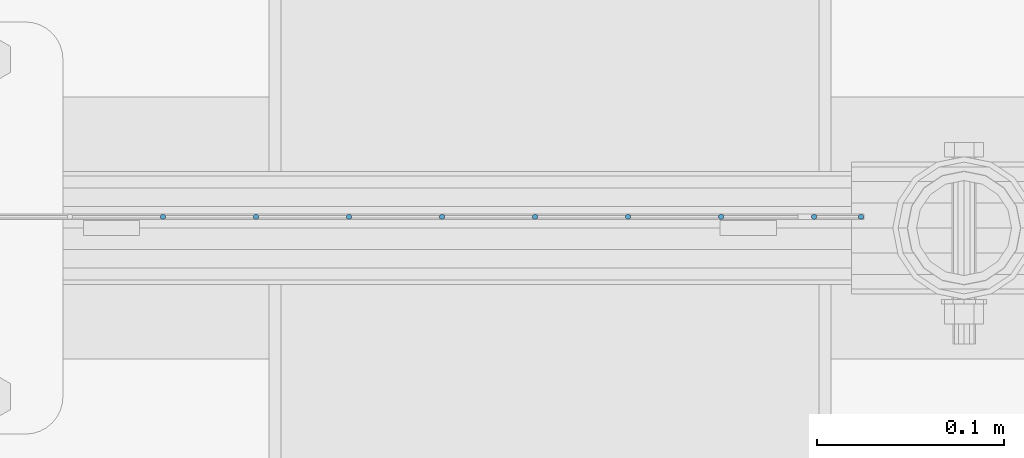
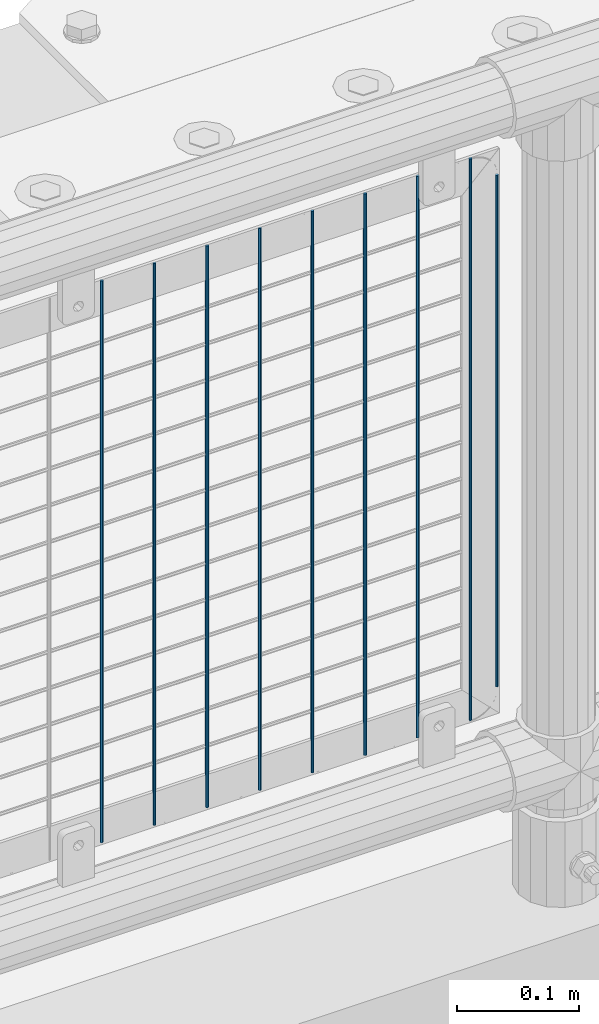
# One storey, part 64 of 208: 9 columns.
"""IFC2X3 building model written with IfcOpenShell, lengths in millimetres."""

from ifc_helpers import new_model, si_unit, frame, origin_with_axes, place, context, subcontext, project, spatial, faceted_brep, material, type_object, element, save


model = new_model("IFC2X3")

# Units and contexts
model_context = context("Model", 3, precision=1e-05, world=origin_with_axes())
body_context = subcontext(model_context, "Body", "Model", "MODEL_VIEW")
ifc_project = project(units=[si_unit("LENGTHUNIT", "METRE", prefix="MILLI"), si_unit("AREAUNIT", "SQUARE_METRE"), si_unit("VOLUMEUNIT", "CUBIC_METRE"), si_unit("MASSUNIT", "GRAM", prefix="KILO"), si_unit("TIMEUNIT", "SECOND"), si_unit("PLANEANGLEUNIT", "RADIAN"), si_unit("SOLIDANGLEUNIT", "STERADIAN"), si_unit("THERMODYNAMICTEMPERATUREUNIT", "DEGREE_CELSIUS"), si_unit("LUMINOUSINTENSITYUNIT", "LUMEN")], contexts=[model_context])

# Site, building, storey
site_placement = place(None, origin_with_axes())
site = spatial("IfcSite", under=ifc_project, at=site_placement, CompositionType="ELEMENT")
building_placement = place(site_placement, origin_with_axes())
building = spatial("IfcBuilding", under=site, at=building_placement, Name="Standard", CompositionType="ELEMENT")
storey_placement = place(building_placement, origin_with_axes())
storey = spatial("IfcBuildingStorey", under=building, at=storey_placement, Name="Undefined", CompositionType="ELEMENT", Elevation=0.0)

# Columns
ifc_material = material(Name="Misc_Undefined")
column_type = type_object("IfcColumnType", Name="D3", PredefinedType="NOTDEFINED")
for number, where, z_axis, x_axis in (
    (1, (-37109.005, 4670.5, 353.02), (-1.0, 0.0, 0.0), (0.0, 0.0, 1.0)),
    (2, (-37158.66, 4670.5, 353.02), (-1.0, 0.0, 0.0), (0.0, 0.0, 1.0)),
    (3, (-37208.315, 4670.5, 353.02), (-1.0, 0.0, 0.0), (0.0, 0.0, 1.0)),
    (4, (-37257.97, 4670.5, 353.02), (-1.0, 0.0, 0.0), (0.0, 0.0, 1.0)),
    (5, (-37307.625, 4670.5, 353.02), (-1.0, 0.0, 0.0), (0.0, 0.0, 1.0)),
    (6, (-37357.28, 4670.5, 353.02), (-1.0, 0.0, 0.0), (0.0, 0.0, 1.0)),
    (7, (-37406.935, 4670.5, 353.02), (-1.0, 0.0, 0.0), (0.0, 0.0, 1.0)),
    (8, (-37456.59, 4670.5, 353.02), (-1.0, 0.0, 0.0), (0.0, 0.0, 1.0)),
):
    element("IfcColumn", number, at=place(storey_placement, frame(where, z_axis=z_axis, x_axis=x_axis)), inside=storey, type_object=column_type, material=ifc_material, ObjectType="D3", context=body_context, shape_type="Brep", body=[
        faceted_brep([(0.0, -1.49999999999909, 3.63797880709171e-12), (-7.27595761418343e-12, -0.749999999999091, -1.29903810567669), (560.0, -0.75, -1.29903810567703), (560.0, -1.5, 0.0), (-3.63797880709171e-12, 0.750000000000909, -1.29903810567669), (560.0, 0.75, -1.29903810567703), (0.0, 1.50000000000182, 3.63797880709171e-12), (560.0, 1.5, 0.0), (-3.63797880709171e-12, 0.750000000000909, 1.29903810567669), (560.0, 0.75, 1.29903810567703), (-7.27595761418343e-12, -0.749999999999091, 1.29903810567669), (560.0, -0.75, 1.29903810567703)], [[[0, 1, 2, 3]], [[1, 4, 5, 2]], [[4, 6, 7, 5]], [[6, 8, 9, 7]], [[8, 10, 11, 9]], [[10, 0, 3, 11]], [[5, 7, 9, 11, 3, 2]], [[10, 8, 6, 4, 1, 0]]]),
    ])
column_placement = place(storey_placement, frame((-37084.0, 4670.5, 378.02), z_axis=(-1.0, 0.0, 0.0), x_axis=(0.0, 0.0, 1.0)))
element("IfcColumn", 9, at=column_placement, inside=storey, type_object=column_type, material=ifc_material, ObjectType="D3", context=body_context, shape_type="Brep", body=[
    faceted_brep([(0.0, -1.49999999999909, 3.63797880709171e-12), (-7.27595761418343e-12, -0.749999999999091, -1.29903810567669), (510.0, -0.75, -1.29903810567703), (510.0, -1.5, 0.0), (-3.63797880709171e-12, 0.750000000000909, -1.29903810567669), (510.0, 0.75, -1.29903810567703), (0.0, 1.50000000000182, 3.63797880709171e-12), (510.0, 1.5, 0.0), (-3.63797880709171e-12, 0.750000000000909, 1.29903810567669), (510.0, 0.75, 1.29903810567703), (-7.27595761418343e-12, -0.749999999999091, 1.29903810567669), (510.0, -0.75, 1.29903810567703)], [[[0, 1, 2, 3]], [[1, 4, 5, 2]], [[4, 6, 7, 5]], [[6, 8, 9, 7]], [[8, 10, 11, 9]], [[10, 0, 3, 11]], [[5, 7, 9, 11, 3, 2]], [[10, 8, 6, 4, 1, 0]]]),
])

save(model, "model.ifc")
